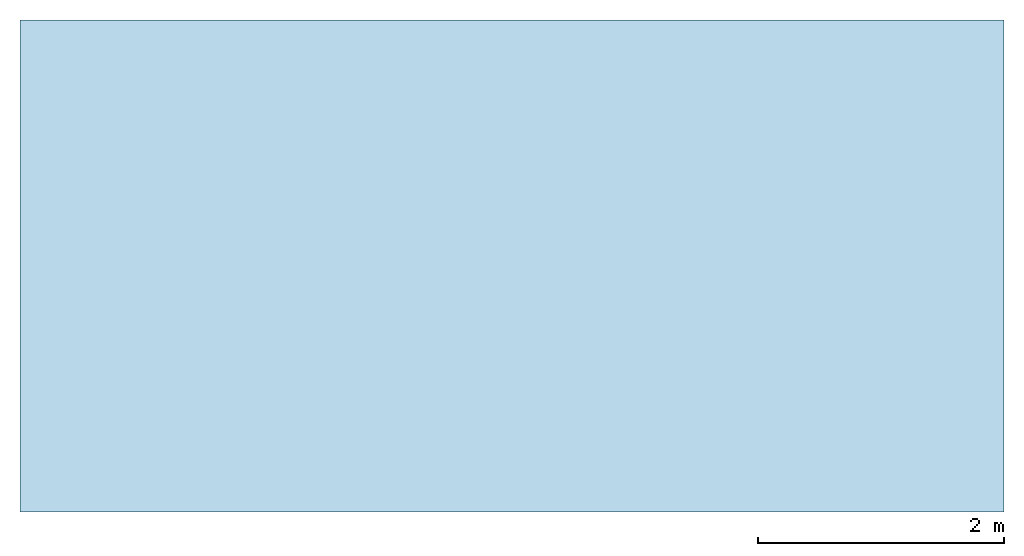
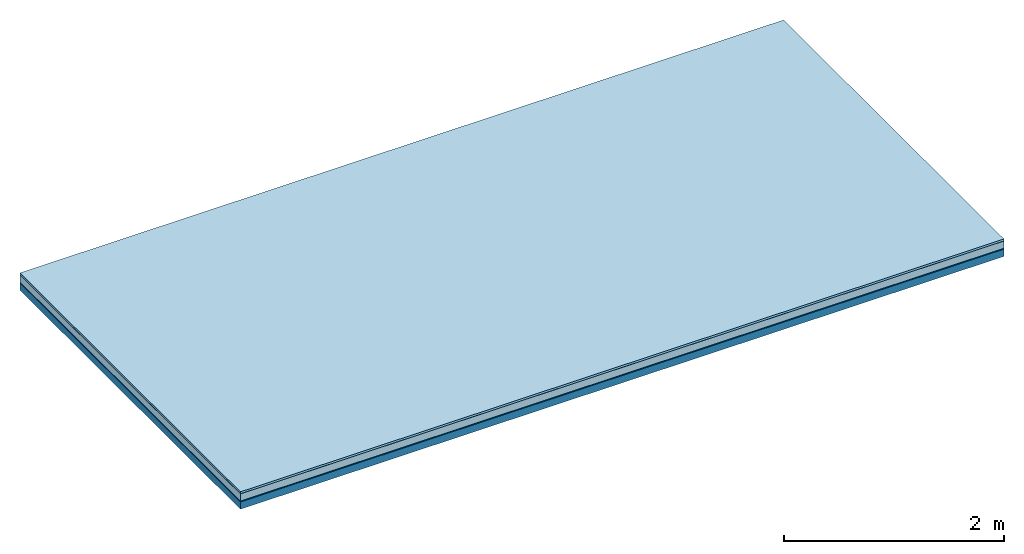
# One storey: 5 plates, 1 member, 1 element without a shape of its own.
"""IFC4 building model written with IfcOpenShell, lengths in metres."""

import ifcopenshell
import ifcopenshell.guid

model = None  # the IFC model being written
_history = None  # IfcOwnerHistory: only IFC2X3 demands one
_inside = {}  # id of a spatial element -> (the spatial element, [elements in it])
_under = {}  # id of a project, library or spatial element -> (it, [spatial elements below it])
_declared = {}  # id of a project -> (the project, [libraries it declares])
_typed = {}  # id of a type object -> (the type object, [elements of that type])
_made_of = {}  # id of a material, layer set ... -> (it, [elements and type objects made of it])


def new_model(schema):
    """Start an empty IFC model of exactly this schema.

    Asked for "IFC4X3", IfcOpenShell would pick the latest addendum, in which some entities
    have other attributes; the version numbers below select the first issue.
    IFC2X3 requires an IfcOwnerHistory on every rooted entity: one is made here for all.
    """
    global model, _history
    if schema == "IFC4X3":
        model = ifcopenshell.file(schema_version=(4, 3, 0, 0))
    else:
        model = ifcopenshell.file(schema=schema)
    _inside.clear()
    _under.clear()
    _declared.clear()
    _typed.clear()
    _made_of.clear()
    _history = None
    if model.schema == "IFC2X3":
        org = make("IfcOrganization", Name="unknown")
        user = make(
            "IfcPersonAndOrganization",
            ThePerson=make("IfcPerson", FamilyName="unknown"),
            TheOrganization=org,
        )
        app = make(
            "IfcApplication",
            ApplicationDeveloper=org,
            Version="unknown",
            ApplicationFullName="unknown",
            ApplicationIdentifier="unknown",
        )
        _history = make(
            "IfcOwnerHistory",
            OwningUser=user,
            OwningApplication=app,
            ChangeAction="ADDED",
            CreationDate=0,
        )
    return model


def make(cls, **values):
    """One entity of the class cls with the attributes given. An attribute that is None is left unset."""
    return model.create_entity(
        cls, **{name: value for name, value in values.items() if value is not None}
    )


def rooted(cls, **values):
    """An entity with a GlobalId (a new one), such as an element, a storey or a relation."""
    return make(cls, GlobalId=ifcopenshell.guid.new(), OwnerHistory=_history, **values)


def si_unit(unit_type, name, prefix=None):
    """IfcSIUnit, for example si_unit("LENGTHUNIT", "METRE", prefix="MILLI")."""
    return make("IfcSIUnit", UnitType=unit_type, Prefix=prefix, Name=name)


def derived_unit(unit_type, elements):
    """IfcDerivedUnit: a product of units, each with its exponent."""
    return make(
        "IfcDerivedUnit",
        Elements=[
            make("IfcDerivedUnitElement", Unit=unit, Exponent=power)
            for unit, power in elements
        ],
        UnitType=unit_type,
    )


def assignment(units):
    """IfcUnitAssignment: the units of a project."""
    return None if units is None else make("IfcUnitAssignment", Units=units)


def point(xyz):
    """IfcCartesianPoint."""
    return None if xyz is None else make("IfcCartesianPoint", Coordinates=xyz)


def direction(xyz):
    """IfcDirection."""
    return None if xyz is None else make("IfcDirection", DirectionRatios=xyz)


def frame(location, z_axis=None, x_axis=None):
    """IfcAxis2Placement3D, a coordinate frame: its origin and axes. An axis left out is left unset."""
    return make(
        "IfcAxis2Placement3D",
        Location=point(location),
        Axis=direction(z_axis),
        RefDirection=direction(x_axis),
    )


def frame_2d(location, x_axis=None):
    """IfcAxis2Placement2D, a coordinate frame in the plane: its origin and x axis."""
    return make(
        "IfcAxis2Placement2D", Location=point(location), RefDirection=direction(x_axis)
    )


def origin():
    """The frame at (0, 0, 0) with its axes left unset."""
    return frame((0.0, 0.0, 0.0))


def origin_with_axes():
    """The frame at (0, 0, 0) with the z axis (0, 0, 1) and the x axis (1, 0, 0) written out."""
    return frame((0.0, 0.0, 0.0), z_axis=(0.0, 0.0, 1.0), x_axis=(1.0, 0.0, 0.0))


def place(relative_to, where):
    """IfcLocalPlacement: puts the frame where relative to a parent placement (None: the world)."""
    return make(
        "IfcLocalPlacement", PlacementRelTo=relative_to, RelativePlacement=where
    )


def context(
    kind, dimensions, precision=None, world=None, true_north=None, identifier=None
):
    """IfcGeometricRepresentationContext, for example the 3D "Model" context."""
    return make(
        "IfcGeometricRepresentationContext",
        ContextIdentifier=identifier,
        ContextType=kind,
        CoordinateSpaceDimension=dimensions,
        Precision=precision,
        WorldCoordinateSystem=world,
        TrueNorth=true_north,
    )


def project(units=None, contexts=None):
    """IfcProject with its units and contexts."""
    return rooted(
        "IfcProject",
        Name="project",
        RepresentationContexts=contexts,
        UnitsInContext=assignment(units),
    )


def spatial(cls, under=None, at=None, **own):
    """A site, building, storey or space (cls), placed at a placement, below another one or the project."""
    s = rooted(cls, ObjectPlacement=at, **own)
    if under is not None:
        _under.setdefault(under.id(), (under, []))[1].append(s)
    return s


def profile(cls, at=None, kind="AREA", **sizes):
    """A parametric profile (cls). Its sizes go by their IFC names, for example OverallWidth=200.0."""
    return make(cls, ProfileType=kind, Position=at, **sizes)


def rectangle(**sizes):
    """IfcRectangleProfileDef."""
    return profile("IfcRectangleProfileDef", **sizes)


def extrude(swept, where, along, depth):
    """IfcExtrudedAreaSolid: the profile swept, set in the frame where, extruded along a direction by depth."""
    return make(
        "IfcExtrudedAreaSolid",
        SweptArea=swept,
        Position=where,
        ExtrudedDirection=direction(along),
        Depth=depth,
    )


def shape(context_of_items, identifier, shape_type, items):
    """IfcShapeRepresentation: the items that make up one representation, for example the "Body"."""
    return make(
        "IfcShapeRepresentation",
        ContextOfItems=context_of_items,
        RepresentationIdentifier=identifier,
        RepresentationType=shape_type,
        Items=items,
    )


def material(Name=None, Category=None):
    """IfcMaterial."""
    return make("IfcMaterial", Name=Name, Category=Category)


def layer(
    of_material, thickness, ventilated=None, Name=None, Category=None, Priority=None
):
    """IfcMaterialLayer: one layer of a wall or slab, of a material (None: an air gap)."""
    return make(
        "IfcMaterialLayer",
        Material=of_material,
        LayerThickness=thickness,
        IsVentilated=ventilated,
        Name=Name,
        Category=Category,
        Priority=Priority,
    )


def layer_set(layers, Name=None):
    """IfcMaterialLayerSet."""
    return make("IfcMaterialLayerSet", MaterialLayers=layers, LayerSetName=Name)


def made_of(thing, what):
    """Note that an element or type object is made of a material, layer set ...; save() writes the relation."""
    if what is not None:
        _made_of.setdefault(what.id(), (what, []))[1].append(thing)
    return thing


def type_object(cls, material=None, **own):
    """A type object (cls), such as IfcWallType, which elements share."""
    return made_of(rooted(cls, **own), material)


def element(
    cls,
    number,
    at=None,
    inside=None,
    cuts=None,
    type_object=None,
    material=None,
    context=None,
    identifier="Body",
    shape_type=None,
    held_by="IfcProductDefinitionShape",
    body=None,
    shapes=None,
    **own,
):
    """One element of the class cls, such as IfcWall. Its Tag is "e" and its number.

    at: its placement. inside: the storey or other place that contains it. cuts: it is an
    opening in that element (IfcRelVoidsElement). A single representation is given by context,
    identifier, shape_type and body (its items); several are given by shapes. held_by: the class
    of the entity that holds the representations. save() writes the other relations.
    """
    e = rooted(cls, Tag="e%d" % number, ObjectPlacement=at, **own)
    if body is not None:
        shapes = [shape(context, identifier, shape_type, body)]
    if shapes is not None:
        e.Representation = make(held_by, Representations=shapes)
    if inside is not None:
        _inside.setdefault(inside.id(), (inside, []))[1].append(e)
    if cuts is not None:
        rooted(
            "IfcRelVoidsElement", RelatingBuildingElement=cuts, RelatedOpeningElement=e
        )
    if type_object is not None:
        _typed.setdefault(type_object.id(), (type_object, []))[1].append(e)
    return made_of(e, material)


def aggregate(whole, parts):
    """IfcRelAggregates: a whole, such as a stair, and the parts it consists of."""
    return rooted("IfcRelAggregates", RelatingObject=whole, RelatedObjects=parts)


def save(model, path):
    """Write the relations noted so far, then the file.

    IfcRelAggregates (storeys below a building ...), IfcRelContainedInSpatialStructure (elements
    in a storey), IfcRelDefinesByType, IfcRelAssociatesMaterial and IfcRelDeclares: one each for
    every whole, place, type object, material and project.
    """
    for whole, parts in _under.values():
        aggregate(whole, parts)
    for where, things in _inside.values():
        rooted(
            "IfcRelContainedInSpatialStructure",
            RelatedElements=things,
            RelatingStructure=where,
        )
    for kind, things in _typed.values():
        rooted("IfcRelDefinesByType", RelatedObjects=things, RelatingType=kind)
    for what, things in _made_of.values():
        rooted("IfcRelAssociatesMaterial", RelatedObjects=things, RelatingMaterial=what)
    for by, libraries in _declared.values():
        rooted("IfcRelDeclares", RelatingContext=by, RelatedDefinitions=libraries)
    model.write(path)


model = new_model("IFC4")

# Units and contexts
plan_context = context("Plan", 3, precision=1e-05, world=origin(), true_north=direction((0.0, 1.0)))
model_context = context("Model", 3, precision=1e-05, world=origin(), true_north=direction((0.0, 1.0)))
ifc_project = project(units=[si_unit("LENGTHUNIT", "METRE"), derived_unit("SOUNDPRESSUREUNIT", [(si_unit("PRESSUREUNIT", "PASCAL", prefix="MICRO"), 0)]), si_unit("ENERGYUNIT", "JOULE", prefix="MEGA"), si_unit("MASSUNIT", "GRAM", prefix="KILO"), derived_unit("THERMALTRANSMITTANCEUNIT", [(si_unit("POWERUNIT", "WATT"), 1), (si_unit("AREAUNIT", "SQUARE_METRE"), -1), (si_unit("THERMODYNAMICTEMPERATUREUNIT", "KELVIN"), -1)]), derived_unit("AREADENSITYUNIT", [(si_unit("MASSUNIT", "GRAM", prefix="KILO"), 1), (si_unit("AREAUNIT", "SQUARE_METRE"), -1)]), derived_unit("USERDEFINED", [(si_unit("ENERGYUNIT", "JOULE", prefix="MEGA"), 1), (si_unit("AREAUNIT", "SQUARE_METRE"), -1)])], contexts=[plan_context, model_context])

# Site, building, storey
site = spatial("IfcSite", under=ifc_project)
building_placement = place(None, origin())
building = spatial("IfcBuilding", under=site, at=building_placement)
storey_placement = place(building_placement, origin())
storey = spatial("IfcBuildingStorey", under=building, at=storey_placement)

# Slab, member, plates
ifc_material_1 = material(Name="with tongue and groove", Category="07.009")
ifc_layer_1 = layer(ifc_material_1, 0.022, Name="Flooring")
ifc_material_2 = material(Category="09.006")
ifc_layer_2 = layer(ifc_material_2, 0.0005, Name="layer")
ifc_material_3 = material(Category="07.011")
ifc_layer_3 = layer(ifc_material_3, 0.08, Name="On-material")
ifc_material_4 = material(Name="Wood fiber generic product", Category="10.009")
ifc_layer_4 = layer(ifc_material_4, 0.01, Name="Impact sound insulation")
ifc_material_5 = material(Name="protection", Category="09.007")
ifc_layer_5 = layer(ifc_material_5, 0.0005, Name="Sub-floor")
ifc_material_6 = material(Name="no composite action")
ifc_layer_6 = layer(ifc_material_6, 0.0, Name="Bond")
ifc_layer_7 = layer(None, 0.08, Name="Supporting structure")
ifc_layer_set = layer_set([ifc_layer_1, ifc_layer_2, ifc_layer_3, ifc_layer_4, ifc_layer_5, ifc_layer_6, ifc_layer_7])
slab_type = type_object("IfcSlabType", Name="A2013", PredefinedType="NOTDEFINED", material=ifc_layer_set)
slab_placement = place(None, frame((0.0, 0.0, 0.0), z_axis=(0.0, 0.0, -1.0), x_axis=(1.0, 0.0, 0.0)))
slab = element("IfcSlab", 1, at=slab_placement, inside=storey, type_object=slab_type, material=ifc_layer_set, Name="Slab #1")
ifc_material_7 = material(Name="Solid timber panel")
member_placement = place(slab_placement, origin())
member = element("IfcMember", 2, at=member_placement, material=ifc_material_7, Name="Supporting structure", context=plan_context, shape_type="SweptSolid", body=[
    extrude(rectangle(XDim=1.0, YDim=0.08, at=frame_2d((0.5, 0.04), x_axis=(1.0, 0.0))), frame((0.0, 4.0, 0.113), z_axis=(0.0, -1.0, 0.0), x_axis=(1.0, 0.0, 0.0)), (0.0, 0.0, 1.0), 4.0),
    extrude(rectangle(XDim=1.0, YDim=0.08, at=frame_2d((0.5, 0.04), x_axis=(1.0, 0.0))), frame((1.0, 4.0, 0.113), z_axis=(0.0, -1.0, 0.0), x_axis=(1.0, 0.0, 0.0)), (0.0, 0.0, 1.0), 4.0),
    extrude(rectangle(XDim=1.0, YDim=0.08, at=frame_2d((0.5, 0.04), x_axis=(1.0, 0.0))), frame((2.0, 4.0, 0.113), z_axis=(0.0, -1.0, 0.0), x_axis=(1.0, 0.0, 0.0)), (0.0, 0.0, 1.0), 4.0),
    extrude(rectangle(XDim=1.0, YDim=0.08, at=frame_2d((0.5, 0.04), x_axis=(1.0, 0.0))), frame((3.0, 4.0, 0.113), z_axis=(0.0, -1.0, 0.0), x_axis=(1.0, 0.0, 0.0)), (0.0, 0.0, 1.0), 4.0),
    extrude(rectangle(XDim=1.0, YDim=0.08, at=frame_2d((0.5, 0.04), x_axis=(1.0, 0.0))), frame((4.0, 4.0, 0.113), z_axis=(0.0, -1.0, 0.0), x_axis=(1.0, 0.0, 0.0)), (0.0, 0.0, 1.0), 4.0),
    extrude(rectangle(XDim=1.0, YDim=0.08, at=frame_2d((0.5, 0.04), x_axis=(1.0, 0.0))), frame((5.0, 4.0, 0.113), z_axis=(0.0, -1.0, 0.0), x_axis=(1.0, 0.0, 0.0)), (0.0, 0.0, 1.0), 4.0),
    extrude(rectangle(XDim=1.0, YDim=0.08, at=frame_2d((0.5, 0.04), x_axis=(1.0, 0.0))), frame((6.0, 4.0, 0.113), z_axis=(0.0, -1.0, 0.0), x_axis=(1.0, 0.0, 0.0)), (0.0, 0.0, 1.0), 4.0),
    extrude(rectangle(XDim=1.0, YDim=0.08, at=frame_2d((0.5, 0.04), x_axis=(1.0, 0.0))), frame((7.0, 4.0, 0.113), z_axis=(0.0, -1.0, 0.0), x_axis=(1.0, 0.0, 0.0)), (0.0, 0.0, 1.0), 4.0),
])
plate_1_placement = place(slab_placement, origin())
plate_1 = element("IfcPlate", 3, at=plate_1_placement, material=ifc_material_1, Name="Flooring", context=plan_context, shape_type="SweptSolid", body=[
    extrude(rectangle(XDim=8.0, YDim=4.0, at=frame_2d((4.0, 2.0), x_axis=(1.0, 0.0))), origin_with_axes(), (0.0, 0.0, 1.0), 0.022),
])
plate_2_placement = place(slab_placement, origin())
plate_2 = element("IfcPlate", 4, at=plate_2_placement, material=ifc_material_2, Name="layer", context=plan_context, shape_type="SweptSolid", body=[
    extrude(rectangle(XDim=8.0, YDim=4.0, at=frame_2d((4.0, 2.0), x_axis=(1.0, 0.0))), frame((0.0, 0.0, 0.022), z_axis=(0.0, 0.0, 1.0), x_axis=(1.0, 0.0, 0.0)), (0.0, 0.0, 1.0), 0.0005),
])
plate_3_placement = place(slab_placement, origin())
plate_3 = element("IfcPlate", 5, at=plate_3_placement, material=ifc_material_3, Name="On-material", context=plan_context, shape_type="SweptSolid", body=[
    extrude(rectangle(XDim=8.0, YDim=4.0, at=frame_2d((4.0, 2.0), x_axis=(1.0, 0.0))), frame((0.0, 0.0, 0.0225), z_axis=(0.0, 0.0, 1.0), x_axis=(1.0, 0.0, 0.0)), (0.0, 0.0, 1.0), 0.08),
])
plate_4_placement = place(slab_placement, origin())
plate_4 = element("IfcPlate", 6, at=plate_4_placement, material=ifc_material_4, Name="Impact sound insulation", context=plan_context, shape_type="SweptSolid", body=[
    extrude(rectangle(XDim=8.0, YDim=4.0, at=frame_2d((4.0, 2.0), x_axis=(1.0, 0.0))), frame((0.0, 0.0, 0.1025), z_axis=(0.0, 0.0, 1.0), x_axis=(1.0, 0.0, 0.0)), (0.0, 0.0, 1.0), 0.01),
])
plate_5_placement = place(slab_placement, origin())
plate_5 = element("IfcPlate", 7, at=plate_5_placement, material=ifc_material_5, Name="Sub-floor", context=plan_context, shape_type="SweptSolid", body=[
    extrude(rectangle(XDim=8.0, YDim=4.0, at=frame_2d((4.0, 2.0), x_axis=(1.0, 0.0))), frame((0.0, 0.0, 0.1125), z_axis=(0.0, 0.0, 1.0), x_axis=(1.0, 0.0, 0.0)), (0.0, 0.0, 1.0), 0.0005),
])
aggregate(slab, [plate_1, plate_2, plate_3, plate_4, plate_5, member])

save(model, "model.ifc")
